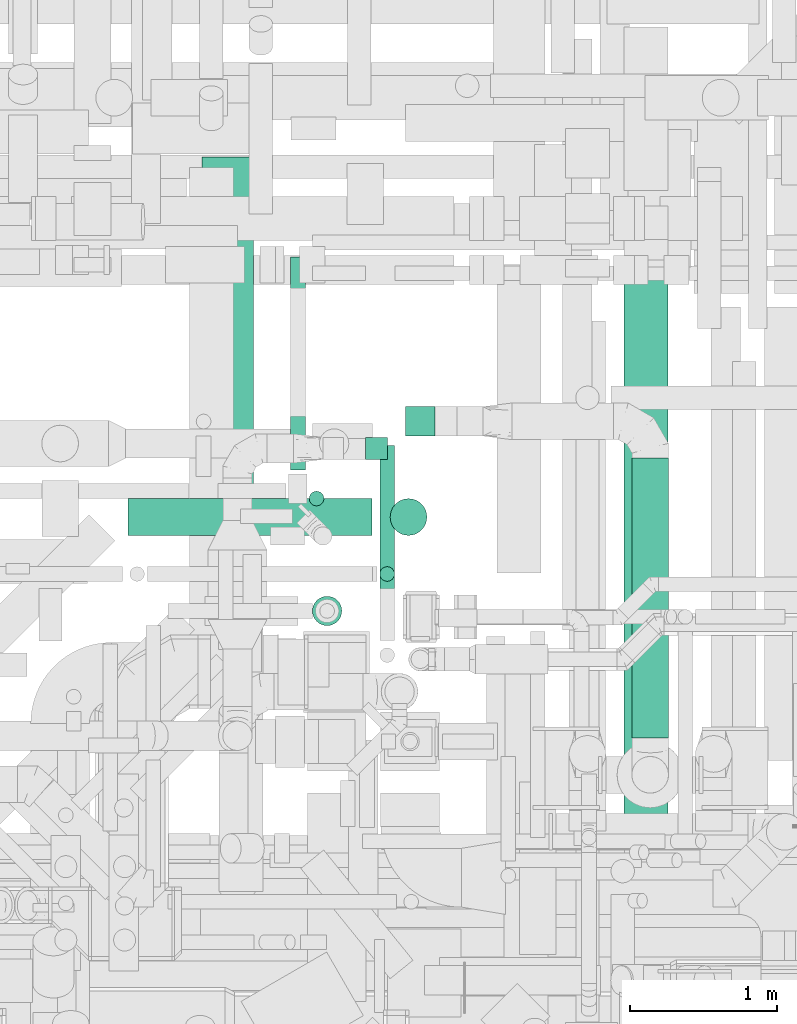
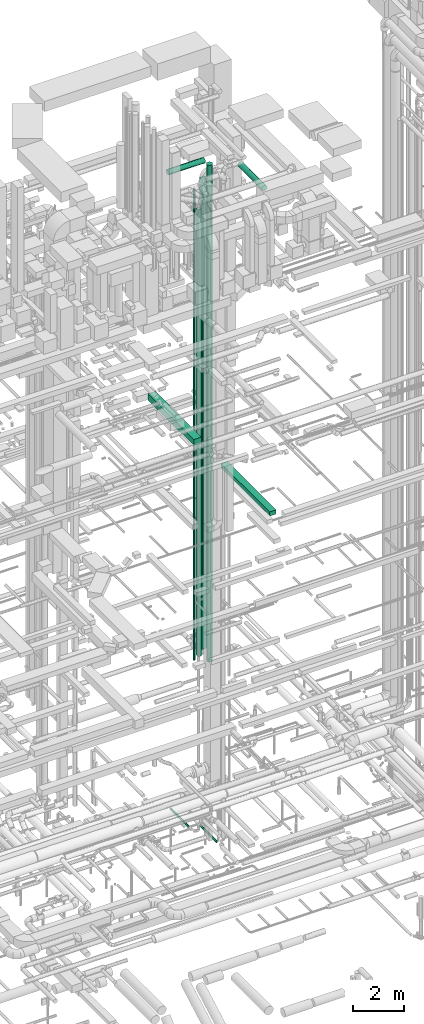
# One storey, part 61 of 337: 12 flow segments.
"""IFC2X3 building model written with IfcOpenShell, lengths in millimetres."""

import ifcopenshell
import ifcopenshell.guid

model = None  # the IFC model being written
_history = None  # IfcOwnerHistory: only IFC2X3 demands one
_inside = {}  # id of a spatial element -> (the spatial element, [elements in it])
_under = {}  # id of a project, library or spatial element -> (it, [spatial elements below it])
_declared = {}  # id of a project -> (the project, [libraries it declares])
_typed = {}  # id of a type object -> (the type object, [elements of that type])
_made_of = {}  # id of a material, layer set ... -> (it, [elements and type objects made of it])


def new_model(schema):
    """Start an empty IFC model of exactly this schema.

    Asked for "IFC4X3", IfcOpenShell would pick the latest addendum, in which some entities
    have other attributes; the version numbers below select the first issue.
    IFC2X3 requires an IfcOwnerHistory on every rooted entity: one is made here for all.
    """
    global model, _history
    if schema == "IFC4X3":
        model = ifcopenshell.file(schema_version=(4, 3, 0, 0))
    else:
        model = ifcopenshell.file(schema=schema)
    _inside.clear()
    _under.clear()
    _declared.clear()
    _typed.clear()
    _made_of.clear()
    _history = None
    if model.schema == "IFC2X3":
        org = make("IfcOrganization", Name="unknown")
        user = make(
            "IfcPersonAndOrganization",
            ThePerson=make("IfcPerson", FamilyName="unknown"),
            TheOrganization=org,
        )
        app = make(
            "IfcApplication",
            ApplicationDeveloper=org,
            Version="unknown",
            ApplicationFullName="unknown",
            ApplicationIdentifier="unknown",
        )
        _history = make(
            "IfcOwnerHistory",
            OwningUser=user,
            OwningApplication=app,
            ChangeAction="ADDED",
            CreationDate=0,
        )
    return model


def make(cls, **values):
    """One entity of the class cls with the attributes given. An attribute that is None is left unset."""
    return model.create_entity(
        cls, **{name: value for name, value in values.items() if value is not None}
    )


def entity(cls, *values):
    """Any entity or typed value of the class cls, its attributes in the order of the schema. None: left unset."""
    e = model.create_entity(cls)
    for i, value in enumerate(values):
        if value is not None:
            e[i] = value
    return e


def rooted(cls, **values):
    """An entity with a GlobalId (a new one), such as an element, a storey or a relation."""
    return make(cls, GlobalId=ifcopenshell.guid.new(), OwnerHistory=_history, **values)


def si_unit(unit_type, name, prefix=None):
    """IfcSIUnit, for example si_unit("LENGTHUNIT", "METRE", prefix="MILLI")."""
    return make("IfcSIUnit", UnitType=unit_type, Prefix=prefix, Name=name)


def converted_unit(unit_type, name, factor, base, dimensions=None, offset=None):
    """IfcConversionBasedUnit, such as the inch: factor (a typed value) times the base unit."""
    return make(
        "IfcConversionBasedUnit"
        if offset is None
        else "IfcConversionBasedUnitWithOffset",
        ConversionOffset=offset,
        Dimensions=None
        if dimensions is None
        else entity("IfcDimensionalExponents", *dimensions),
        UnitType=unit_type,
        Name=name,
        ConversionFactor=make(
            "IfcMeasureWithUnit", ValueComponent=factor, UnitComponent=base
        ),
    )


def derived_unit(unit_type, elements):
    """IfcDerivedUnit: a product of units, each with its exponent."""
    return make(
        "IfcDerivedUnit",
        Elements=[
            make("IfcDerivedUnitElement", Unit=unit, Exponent=power)
            for unit, power in elements
        ],
        UnitType=unit_type,
    )


def assignment(units):
    """IfcUnitAssignment: the units of a project."""
    return None if units is None else make("IfcUnitAssignment", Units=units)


def point(xyz):
    """IfcCartesianPoint."""
    return None if xyz is None else make("IfcCartesianPoint", Coordinates=xyz)


def direction(xyz):
    """IfcDirection."""
    return None if xyz is None else make("IfcDirection", DirectionRatios=xyz)


def frame(location, z_axis=None, x_axis=None):
    """IfcAxis2Placement3D, a coordinate frame: its origin and axes. An axis left out is left unset."""
    return make(
        "IfcAxis2Placement3D",
        Location=point(location),
        Axis=direction(z_axis),
        RefDirection=direction(x_axis),
    )


def frame_2d(location, x_axis=None):
    """IfcAxis2Placement2D, a coordinate frame in the plane: its origin and x axis."""
    return make(
        "IfcAxis2Placement2D", Location=point(location), RefDirection=direction(x_axis)
    )


def origin():
    """The frame at (0, 0, 0) with its axes left unset."""
    return frame((0.0, 0.0, 0.0))


def origin_2d_with_axis():
    """The frame at (0, 0) in the plane with the x axis (1, 0) written out."""
    return frame_2d((0.0, 0.0), x_axis=(1.0, 0.0))


def place(relative_to, where):
    """IfcLocalPlacement: puts the frame where relative to a parent placement (None: the world)."""
    return make(
        "IfcLocalPlacement", PlacementRelTo=relative_to, RelativePlacement=where
    )


def context(
    kind, dimensions, precision=None, world=None, true_north=None, identifier=None
):
    """IfcGeometricRepresentationContext, for example the 3D "Model" context."""
    return make(
        "IfcGeometricRepresentationContext",
        ContextIdentifier=identifier,
        ContextType=kind,
        CoordinateSpaceDimension=dimensions,
        Precision=precision,
        WorldCoordinateSystem=world,
        TrueNorth=true_north,
    )


def subcontext(parent, identifier, kind, view, scale=None):
    """IfcGeometricRepresentationSubContext, for example "Body" below "Model"."""
    return make(
        "IfcGeometricRepresentationSubContext",
        ContextIdentifier=identifier,
        ContextType=kind,
        ParentContext=parent,
        TargetScale=scale,
        TargetView=view,
    )


def project(units=None, contexts=None):
    """IfcProject with its units and contexts."""
    return rooted(
        "IfcProject",
        Name="project",
        RepresentationContexts=contexts,
        UnitsInContext=assignment(units),
    )


def spatial(cls, under=None, at=None, **own):
    """A site, building, storey or space (cls), placed at a placement, below another one or the project."""
    s = rooted(cls, ObjectPlacement=at, **own)
    if under is not None:
        _under.setdefault(under.id(), (under, []))[1].append(s)
    return s


def profile(cls, at=None, kind="AREA", **sizes):
    """A parametric profile (cls). Its sizes go by their IFC names, for example OverallWidth=200.0."""
    return make(cls, ProfileType=kind, Position=at, **sizes)


def rectangle(**sizes):
    """IfcRectangleProfileDef."""
    return profile("IfcRectangleProfileDef", **sizes)


def circle(**sizes):
    """IfcCircleProfileDef."""
    return profile("IfcCircleProfileDef", **sizes)


def extrude(swept, where, along, depth):
    """IfcExtrudedAreaSolid: the profile swept, set in the frame where, extruded along a direction by depth."""
    return make(
        "IfcExtrudedAreaSolid",
        SweptArea=swept,
        Position=where,
        ExtrudedDirection=direction(along),
        Depth=depth,
    )


def shape(context_of_items, identifier, shape_type, items):
    """IfcShapeRepresentation: the items that make up one representation, for example the "Body"."""
    return make(
        "IfcShapeRepresentation",
        ContextOfItems=context_of_items,
        RepresentationIdentifier=identifier,
        RepresentationType=shape_type,
        Items=items,
    )


def made_of(thing, what):
    """Note that an element or type object is made of a material, layer set ...; save() writes the relation."""
    if what is not None:
        _made_of.setdefault(what.id(), (what, []))[1].append(thing)
    return thing


def type_object(cls, material=None, **own):
    """A type object (cls), such as IfcWallType, which elements share."""
    return made_of(rooted(cls, **own), material)


def element(
    cls,
    number,
    at=None,
    inside=None,
    cuts=None,
    type_object=None,
    material=None,
    context=None,
    identifier="Body",
    shape_type=None,
    held_by="IfcProductDefinitionShape",
    body=None,
    shapes=None,
    **own,
):
    """One element of the class cls, such as IfcWall. Its Tag is "e" and its number.

    at: its placement. inside: the storey or other place that contains it. cuts: it is an
    opening in that element (IfcRelVoidsElement). A single representation is given by context,
    identifier, shape_type and body (its items); several are given by shapes. held_by: the class
    of the entity that holds the representations. save() writes the other relations.
    """
    e = rooted(cls, Tag="e%d" % number, ObjectPlacement=at, **own)
    if body is not None:
        shapes = [shape(context, identifier, shape_type, body)]
    if shapes is not None:
        e.Representation = make(held_by, Representations=shapes)
    if inside is not None:
        _inside.setdefault(inside.id(), (inside, []))[1].append(e)
    if cuts is not None:
        rooted(
            "IfcRelVoidsElement", RelatingBuildingElement=cuts, RelatedOpeningElement=e
        )
    if type_object is not None:
        _typed.setdefault(type_object.id(), (type_object, []))[1].append(e)
    return made_of(e, material)


def aggregate(whole, parts):
    """IfcRelAggregates: a whole, such as a stair, and the parts it consists of."""
    return rooted("IfcRelAggregates", RelatingObject=whole, RelatedObjects=parts)


def save(model, path):
    """Write the relations noted so far, then the file.

    IfcRelAggregates (storeys below a building ...), IfcRelContainedInSpatialStructure (elements
    in a storey), IfcRelDefinesByType, IfcRelAssociatesMaterial and IfcRelDeclares: one each for
    every whole, place, type object, material and project.
    """
    for whole, parts in _under.values():
        aggregate(whole, parts)
    for where, things in _inside.values():
        rooted(
            "IfcRelContainedInSpatialStructure",
            RelatedElements=things,
            RelatingStructure=where,
        )
    for kind, things in _typed.values():
        rooted("IfcRelDefinesByType", RelatedObjects=things, RelatingType=kind)
    for what, things in _made_of.values():
        rooted("IfcRelAssociatesMaterial", RelatedObjects=things, RelatingMaterial=what)
    for by, libraries in _declared.values():
        rooted("IfcRelDeclares", RelatingContext=by, RelatedDefinitions=libraries)
    model.write(path)


model = new_model("IFC2X3")

# Units and contexts
model_context = context("Model", 3, precision=0.01, world=origin(), true_north=direction((6.12303176911189e-17, 1.0)))
body_context = subcontext(model_context, "Body", "Model", "MODEL_VIEW")
ifc_project = project(units=[si_unit("LENGTHUNIT", "METRE", prefix="MILLI"), si_unit("AREAUNIT", "SQUARE_METRE"), si_unit("VOLUMEUNIT", "CUBIC_METRE"), converted_unit("PLANEANGLEUNIT", "DEGREE", entity("IfcRatioMeasure", 0.0174532925199433), si_unit("PLANEANGLEUNIT", "RADIAN"), dimensions=[0, 0, 0, 0, 0, 0, 0]), si_unit("MASSUNIT", "GRAM", prefix="KILO"), derived_unit("MASSDENSITYUNIT", [(si_unit("MASSUNIT", "GRAM", prefix="KILO"), 1), (si_unit("LENGTHUNIT", "METRE"), -3)]), derived_unit("MOMENTOFINERTIAUNIT", [(si_unit("LENGTHUNIT", "METRE"), 4)]), si_unit("TIMEUNIT", "SECOND"), si_unit("FREQUENCYUNIT", "HERTZ"), si_unit("THERMODYNAMICTEMPERATUREUNIT", "DEGREE_CELSIUS"), derived_unit("THERMALTRANSMITTANCEUNIT", [(si_unit("MASSUNIT", "GRAM", prefix="KILO"), 1), (si_unit("THERMODYNAMICTEMPERATUREUNIT", "KELVIN"), -1), (si_unit("TIMEUNIT", "SECOND"), -3)]), derived_unit("VOLUMETRICFLOWRATEUNIT", [(si_unit("LENGTHUNIT", "METRE"), 3), (si_unit("TIMEUNIT", "SECOND"), -1)]), derived_unit("MASSFLOWRATEUNIT", [(si_unit("MASSUNIT", "GRAM", prefix="KILO"), 1), (si_unit("TIMEUNIT", "SECOND"), -1)]), derived_unit("ROTATIONALFREQUENCYUNIT", [(si_unit("TIMEUNIT", "SECOND"), -1)]), si_unit("ELECTRICCURRENTUNIT", "AMPERE"), si_unit("ELECTRICVOLTAGEUNIT", "VOLT"), si_unit("POWERUNIT", "WATT"), si_unit("FORCEUNIT", "NEWTON", prefix="KILO"), si_unit("ILLUMINANCEUNIT", "LUX"), si_unit("LUMINOUSFLUXUNIT", "LUMEN"), si_unit("LUMINOUSINTENSITYUNIT", "CANDELA"), derived_unit("USERDEFINED", [(si_unit("MASSUNIT", "GRAM", prefix="KILO"), -1), (si_unit("LENGTHUNIT", "METRE"), -2), (si_unit("TIMEUNIT", "SECOND"), 3), (si_unit("LUMINOUSFLUXUNIT", "LUMEN"), 1)]), derived_unit("LINEARVELOCITYUNIT", [(si_unit("LENGTHUNIT", "METRE"), 1), (si_unit("TIMEUNIT", "SECOND"), -1)]), si_unit("PRESSUREUNIT", "PASCAL"), derived_unit("USERDEFINED", [(si_unit("LENGTHUNIT", "METRE"), -2), (si_unit("MASSUNIT", "GRAM", prefix="KILO"), 1), (si_unit("TIMEUNIT", "SECOND"), -2)]), derived_unit("LINEARFORCEUNIT", [(si_unit("MASSUNIT", "GRAM", prefix="KILO"), 1), (si_unit("LENGTHUNIT", "METRE"), 1), (si_unit("TIMEUNIT", "SECOND"), -2), (si_unit("LENGTHUNIT", "METRE"), -1)]), derived_unit("PLANARFORCEUNIT", [(si_unit("MASSUNIT", "GRAM", prefix="KILO"), 1), (si_unit("LENGTHUNIT", "METRE"), 1), (si_unit("TIMEUNIT", "SECOND"), -2), (si_unit("LENGTHUNIT", "METRE"), -2)])], contexts=[model_context])

# Site, building, storey
site_placement = place(None, origin())
site = spatial("IfcSite", under=ifc_project, at=site_placement, CompositionType="ELEMENT")
building_placement = place(site_placement, origin())
building = spatial("IfcBuilding", under=site, at=building_placement, CompositionType="ELEMENT")
storey_placement = place(building_placement, origin())
storey = spatial("IfcBuildingStorey", under=building, at=storey_placement, CompositionType="ELEMENT", Elevation=0.0)

# Flow segments
duct_segment_type_1 = type_object("IfcDuctSegmentType", PredefinedType="NOTDEFINED")
flow_segment_1_placement = place(storey_placement, frame((60938.43, 10274.99, 15250.0)))
element("IfcFlowSegment", 1, at=flow_segment_1_placement, inside=storey, type_object=duct_segment_type_1, context=body_context, shape_type="SweptSolid", body=[
    extrude(rectangle(XDim=3861.4032379077, YDim=300.000000000001, at=origin_2d_with_axis()), frame((150.0, 1930.7, 0.0), z_axis=(0.0, 0.0, 1.0), x_axis=(0.0, 1.0, 0.0)), (0.0, 0.0, 1.0), 199.999999999998),
])
flow_segment_2_placement = place(storey_placement, frame((58064.44, 11289.64, 19034.58)))
element("IfcFlowSegment", 2, at=flow_segment_2_placement, inside=storey, type_object=duct_segment_type_1, context=body_context, shape_type="SweptSolid", body=[
    extrude(rectangle(XDim=3654.70335479438, YDim=349.999999999998, at=origin_2d_with_axis()), frame((175.0, 1827.35, 0.0), z_axis=(0.0, 0.0, 1.0), x_axis=(0.0, 1.0, 0.0)), (0.0, 0.0, 1.0), 300.000000000001),
])
flow_segment_3_placement = place(storey_placement, frame((59449.99, 13045.23, 7644.59)))
element("IfcFlowSegment", 3, at=flow_segment_3_placement, inside=storey, type_object=duct_segment_type_1, context=body_context, shape_type="SweptSolid", body=[
    extrude(rectangle(XDim=199.999999999998, YDim=199.999999999998, at=origin_2d_with_axis()), frame((100.0, 100.0, 0.0), z_axis=(0.0, 0.0, 1.0), x_axis=(0.0, -1.0, 0.0)), (0.0, 0.0, 1.0), 22705.4108446112),
])
flow_segment_4_placement = place(storey_placement, frame((59176.14, 12885.58, 7475.0)))
element("IfcFlowSegment", 4, at=flow_segment_4_placement, inside=storey, type_object=duct_segment_type_1, context=body_context, shape_type="SweptSolid", body=[
    extrude(rectangle(XDim=150.000000000001, YDim=150.000000000004, at=origin_2d_with_axis()), frame((75.0, 75.0, 0.0), z_axis=(1.81194195456551e-05, 0.0, 1.0), x_axis=(0.0, -1.0, 0.0)), (0.0, 0.0, 1.0), 21599.9959267145),
])
duct_segment_type_2 = type_object("IfcDuctSegmentType", PredefinedType="NOTDEFINED")
flow_segment_5_placement = place(storey_placement, frame((58665.04, 12812.79, -571.6)))
element("IfcFlowSegment", 5, at=flow_segment_5_placement, inside=storey, type_object=duct_segment_type_2, context=body_context, shape_type="SweptSolid", body=[
    extrude(circle(Radius=50.0, at=origin_2d_with_axis()), frame((51.6, 0.0, 51.6), z_axis=(0.0, 1.0, 0.0), x_axis=(1.0, 0.0, 0.0)), (0.0, 0.0, 1.0), 1450.84066384145),
])
flow_segment_6_placement = place(storey_placement, frame((59272.94, 11653.05, -801.6)))
element("IfcFlowSegment", 6, at=flow_segment_6_placement, inside=storey, type_object=duct_segment_type_2, context=body_context, shape_type="SweptSolid", body=[
    extrude(circle(Radius=50.0, at=origin_2d_with_axis()), frame((51.6, 0.0, 51.6), z_axis=(0.0, 1.0, 0.0), x_axis=(1.0, 0.0, 0.0)), (0.0, 0.0, 1.0), 1326.68667),
])
flow_segment_7_placement = place(storey_placement, frame((59272.94, 12054.04, 28700.0)))
element("IfcFlowSegment", 7, at=flow_segment_7_placement, inside=storey, type_object=duct_segment_type_2, context=body_context, shape_type="SweptSolid", body=[
    extrude(circle(Radius=50.0, at=origin_2d_with_axis()), frame((51.6, 51.6, 0.0), z_axis=(0.0, 0.0, 1.0), x_axis=(0.0, 1.0, 0.0)), (0.0, 0.0, 1.0), 1400.41722915464),
])
flow_segment_8_placement = place(storey_placement, frame((60988.7, 10988.49, 30473.4)))
element("IfcFlowSegment", 8, at=flow_segment_8_placement, inside=storey, type_object=duct_segment_type_2, context=body_context, shape_type="SweptSolid", body=[
    extrude(circle(Radius=125.0, at=origin_2d_with_axis()), frame((126.6, 0.0, 126.6), z_axis=(0.0, 1.0, 0.0), x_axis=(1.0, 0.0, 0.0)), (0.0, 0.0, 1.0), 1906.74300067769),
])
flow_segment_9_placement = place(storey_placement, frame((57560.24, 12367.12, 31573.4)))
element("IfcFlowSegment", 9, at=flow_segment_9_placement, inside=storey, type_object=duct_segment_type_2, context=body_context, shape_type="SweptSolid", body=[
    extrude(circle(Radius=125.0, at=origin_2d_with_axis()), frame((0.0, 126.6, 126.6), z_axis=(1.0, 0.0, 0.0), x_axis=(0.0, -1.0, 0.0)), (0.0, 0.0, 1.0), 1659.75456944196),
])
flow_segment_10_placement = place(storey_placement, frame((58814.04, 11752.63, 12160.0)))
element("IfcFlowSegment", 10, at=flow_segment_10_placement, inside=storey, type_object=duct_segment_type_2, context=body_context, shape_type="SweptSolid", body=[
    extrude(circle(Radius=100.0, at=origin_2d_with_axis()), frame((101.6, 101.6, 0.0), z_axis=(0.0, 0.0, 1.0), x_axis=(0.0, -1.0, 0.0)), (0.0, 0.0, 1.0), 18440.0),
])
duct_segment_type_3 = type_object("IfcDuctSegmentType", PredefinedType="NOTDEFINED")
flow_segment_11_placement = place(storey_placement, frame((59343.4, 12367.12, 7450.0)))
element("IfcFlowSegment", 11, at=flow_segment_11_placement, inside=storey, type_object=duct_segment_type_3, context=body_context, shape_type="SweptSolid", body=[
    extrude(circle(Radius=125.0, at=origin_2d_with_axis()), frame((126.6, 126.6, 0.0), z_axis=(0.0, 0.0, 1.0), x_axis=(0.0, 1.0, 0.0)), (0.0, 0.0, 1.0), 24000.0),
])
flow_segment_12_placement = place(storey_placement, frame((58791.97, 12568.13, 7620.0)))
element("IfcFlowSegment", 12, at=flow_segment_12_placement, inside=storey, type_object=duct_segment_type_3, context=body_context, shape_type="SweptSolid", body=[
    extrude(circle(Radius=50.0, at=origin_2d_with_axis()), frame((51.6, 51.6, 0.0), z_axis=(0.0, 0.0, 1.0), x_axis=(0.0, -1.0, 0.0)), (0.0, 0.0, 1.0), 22780.0),
])

save(model, "model.ifc")
